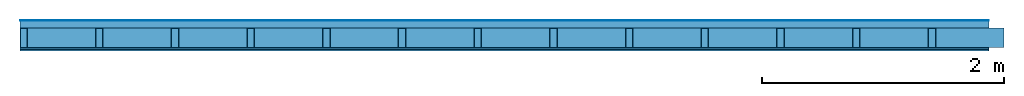
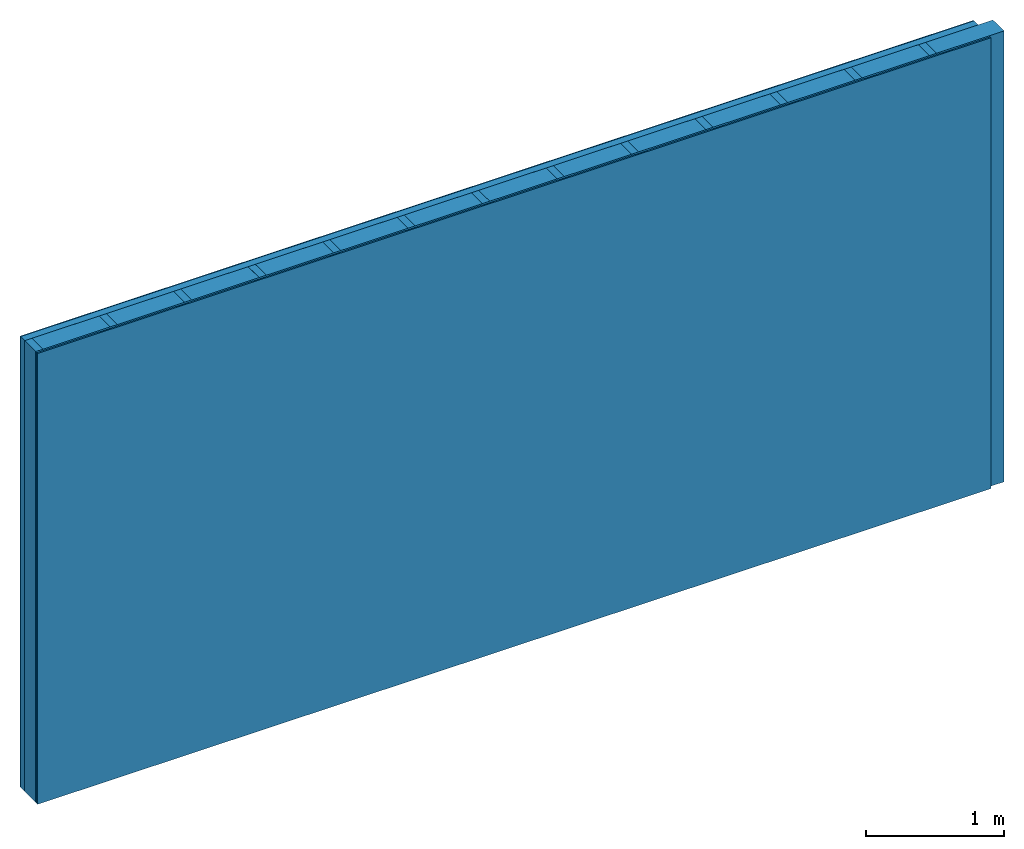
# One storey: 4 plates, 2 members, 1 element without a shape of its own.
"""IFC4 building model written with IfcOpenShell, lengths in metres."""

from ifc_helpers import new_model, si_unit, derived_unit, direction, frame, frame_2d, origin, origin_with_axes, place, context, project, spatial, rectangle, extrude, material, layer, layer_set, type_object, element, aggregate, save


model = new_model("IFC4")

# Units and contexts
plan_context = context("Plan", 3, precision=1e-05, world=origin(), true_north=direction((0.0, 1.0)))
model_context = context("Model", 3, precision=1e-05, world=origin(), true_north=direction((0.0, 1.0)))
ifc_project = project(units=[si_unit("LENGTHUNIT", "METRE"), derived_unit("SOUNDPRESSUREUNIT", [(si_unit("PRESSUREUNIT", "PASCAL", prefix="MICRO"), 0)]), si_unit("ENERGYUNIT", "JOULE", prefix="MEGA"), si_unit("MASSUNIT", "GRAM", prefix="KILO"), derived_unit("THERMALTRANSMITTANCEUNIT", [(si_unit("POWERUNIT", "WATT"), 1), (si_unit("AREAUNIT", "SQUARE_METRE"), -1), (si_unit("THERMODYNAMICTEMPERATUREUNIT", "KELVIN"), -1)]), derived_unit("AREADENSITYUNIT", [(si_unit("MASSUNIT", "GRAM", prefix="KILO"), 1), (si_unit("AREAUNIT", "SQUARE_METRE"), -1)]), derived_unit("USERDEFINED", [(si_unit("ENERGYUNIT", "JOULE", prefix="MEGA"), 1), (si_unit("AREAUNIT", "SQUARE_METRE"), -1)])], contexts=[plan_context, model_context])

# Site, building, storey
site = spatial("IfcSite", under=ifc_project)
building_placement = place(None, origin())
building = spatial("IfcBuilding", under=site, at=building_placement)
storey_placement = place(building_placement, origin())
storey = spatial("IfcBuildingStorey", under=building, at=storey_placement)

# Wall, members, plates
ifc_material_1 = material(Category="04.011")
ifc_layer_1 = layer(ifc_material_1, 0.008, Name="Surface 1")
ifc_material_2 = material(Category="10.009")
ifc_layer_2 = layer(ifc_material_2, 0.06, Name="outside 2nd layer")
ifc_material_3 = material(Name="of the art")
ifc_layer_3 = layer(ifc_material_3, 0.0, Name="Bond")
ifc_layer_4 = layer(None, 0.16, Name="Support")
ifc_material_4 = material(Name="Rigid, of the art")
ifc_layer_5 = layer(ifc_material_4, 0.0, Name="Bond")
ifc_material_5 = material(Name="OSB/3", Category="07.013")
ifc_layer_6 = layer(ifc_material_5, 0.015, Name="1st layer")
ifc_material_6 = material(Category="03.007")
ifc_layer_7 = layer(ifc_material_6, 0.0125, Name="2nd layer")
ifc_material_7 = material(Name="Glued joints")
ifc_layer_8 = layer(ifc_material_7, 0.0, Name="Surface")
ifc_layer_set = layer_set([ifc_layer_1, ifc_layer_2, ifc_layer_3, ifc_layer_4, ifc_layer_5, ifc_layer_6, ifc_layer_7, ifc_layer_8])
wall_type = type_object("IfcWallType", Name="D1188", PredefinedType="NOTDEFINED", material=ifc_layer_set)
wall_placement = place(None, frame((0.0, 0.0, 0.0), z_axis=(0.0, -1.0, 0.0), x_axis=(1.0, 0.0, 0.0)))
wall = element("IfcWall", 1, at=wall_placement, inside=storey, type_object=wall_type, material=ifc_layer_set, Name="Wall #1")
ifc_material_8 = material()
member_1_placement = place(wall_placement, origin())
member_1 = element("IfcMember", 2, at=member_1_placement, material=ifc_material_8, Name="Support", context=plan_context, shape_type="SweptSolid", body=[
    extrude(rectangle(XDim=0.06, YDim=0.16, at=frame_2d((0.03, 0.08), x_axis=(1.0, 0.0))), frame((0.0, 4.0, 0.068), z_axis=(0.0, -1.0, 0.0), x_axis=(1.0, 0.0, 0.0)), (0.0, 0.0, 1.0), 4.0),
    extrude(rectangle(XDim=0.06, YDim=0.16, at=frame_2d((0.03, 0.08), x_axis=(1.0, 0.0))), frame((0.625, 4.0, 0.068), z_axis=(0.0, -1.0, 0.0), x_axis=(1.0, 0.0, 0.0)), (0.0, 0.0, 1.0), 4.0),
    extrude(rectangle(XDim=0.06, YDim=0.16, at=frame_2d((0.03, 0.08), x_axis=(1.0, 0.0))), frame((1.25, 4.0, 0.068), z_axis=(0.0, -1.0, 0.0), x_axis=(1.0, 0.0, 0.0)), (0.0, 0.0, 1.0), 4.0),
    extrude(rectangle(XDim=0.06, YDim=0.16, at=frame_2d((0.03, 0.08), x_axis=(1.0, 0.0))), frame((1.875, 4.0, 0.068), z_axis=(0.0, -1.0, 0.0), x_axis=(1.0, 0.0, 0.0)), (0.0, 0.0, 1.0), 4.0),
    extrude(rectangle(XDim=0.06, YDim=0.16, at=frame_2d((0.03, 0.08), x_axis=(1.0, 0.0))), frame((2.5, 4.0, 0.068), z_axis=(0.0, -1.0, 0.0), x_axis=(1.0, 0.0, 0.0)), (0.0, 0.0, 1.0), 4.0),
    extrude(rectangle(XDim=0.06, YDim=0.16, at=frame_2d((0.03, 0.08), x_axis=(1.0, 0.0))), frame((3.125, 4.0, 0.068), z_axis=(0.0, -1.0, 0.0), x_axis=(1.0, 0.0, 0.0)), (0.0, 0.0, 1.0), 4.0),
    extrude(rectangle(XDim=0.06, YDim=0.16, at=frame_2d((0.03, 0.08), x_axis=(1.0, 0.0))), frame((3.75, 4.0, 0.068), z_axis=(0.0, -1.0, 0.0), x_axis=(1.0, 0.0, 0.0)), (0.0, 0.0, 1.0), 4.0),
    extrude(rectangle(XDim=0.06, YDim=0.16, at=frame_2d((0.03, 0.08), x_axis=(1.0, 0.0))), frame((4.375, 4.0, 0.068), z_axis=(0.0, -1.0, 0.0), x_axis=(1.0, 0.0, 0.0)), (0.0, 0.0, 1.0), 4.0),
    extrude(rectangle(XDim=0.06, YDim=0.16, at=frame_2d((0.03, 0.08), x_axis=(1.0, 0.0))), frame((5.0, 4.0, 0.068), z_axis=(0.0, -1.0, 0.0), x_axis=(1.0, 0.0, 0.0)), (0.0, 0.0, 1.0), 4.0),
    extrude(rectangle(XDim=0.06, YDim=0.16, at=frame_2d((0.03, 0.08), x_axis=(1.0, 0.0))), frame((5.625, 4.0, 0.068), z_axis=(0.0, -1.0, 0.0), x_axis=(1.0, 0.0, 0.0)), (0.0, 0.0, 1.0), 4.0),
    extrude(rectangle(XDim=0.06, YDim=0.16, at=frame_2d((0.03, 0.08), x_axis=(1.0, 0.0))), frame((6.25, 4.0, 0.068), z_axis=(0.0, -1.0, 0.0), x_axis=(1.0, 0.0, 0.0)), (0.0, 0.0, 1.0), 4.0),
    extrude(rectangle(XDim=0.06, YDim=0.16, at=frame_2d((0.03, 0.08), x_axis=(1.0, 0.0))), frame((6.875, 4.0, 0.068), z_axis=(0.0, -1.0, 0.0), x_axis=(1.0, 0.0, 0.0)), (0.0, 0.0, 1.0), 4.0),
    extrude(rectangle(XDim=0.06, YDim=0.16, at=frame_2d((0.03, 0.08), x_axis=(1.0, 0.0))), frame((7.5, 4.0, 0.068), z_axis=(0.0, -1.0, 0.0), x_axis=(1.0, 0.0, 0.0)), (0.0, 0.0, 1.0), 4.0),
])
ifc_material_9 = material()
member_2_placement = place(wall_placement, origin())
member_2 = element("IfcMember", 3, at=member_2_placement, material=ifc_material_9, Name="Cavity", context=plan_context, shape_type="SweptSolid", body=[
    extrude(rectangle(XDim=0.565, YDim=0.16, at=frame_2d((0.2825, 0.08), x_axis=(1.0, 0.0))), frame((0.06, 4.0, 0.068), z_axis=(0.0, -1.0, 0.0), x_axis=(1.0, 0.0, 0.0)), (0.0, 0.0, 1.0), 4.0),
    extrude(rectangle(XDim=0.565, YDim=0.16, at=frame_2d((0.2825, 0.08), x_axis=(1.0, 0.0))), frame((0.685, 4.0, 0.068), z_axis=(0.0, -1.0, 0.0), x_axis=(1.0, 0.0, 0.0)), (0.0, 0.0, 1.0), 4.0),
    extrude(rectangle(XDim=0.565, YDim=0.16, at=frame_2d((0.2825, 0.08), x_axis=(1.0, 0.0))), frame((1.31, 4.0, 0.068), z_axis=(0.0, -1.0, 0.0), x_axis=(1.0, 0.0, 0.0)), (0.0, 0.0, 1.0), 4.0),
    extrude(rectangle(XDim=0.565, YDim=0.16, at=frame_2d((0.2825, 0.08), x_axis=(1.0, 0.0))), frame((1.935, 4.0, 0.068), z_axis=(0.0, -1.0, 0.0), x_axis=(1.0, 0.0, 0.0)), (0.0, 0.0, 1.0), 4.0),
    extrude(rectangle(XDim=0.565, YDim=0.16, at=frame_2d((0.2825, 0.08), x_axis=(1.0, 0.0))), frame((2.56, 4.0, 0.068), z_axis=(0.0, -1.0, 0.0), x_axis=(1.0, 0.0, 0.0)), (0.0, 0.0, 1.0), 4.0),
    extrude(rectangle(XDim=0.565, YDim=0.16, at=frame_2d((0.2825, 0.08), x_axis=(1.0, 0.0))), frame((3.185, 4.0, 0.068), z_axis=(0.0, -1.0, 0.0), x_axis=(1.0, 0.0, 0.0)), (0.0, 0.0, 1.0), 4.0),
    extrude(rectangle(XDim=0.565, YDim=0.16, at=frame_2d((0.2825, 0.08), x_axis=(1.0, 0.0))), frame((3.81, 4.0, 0.068), z_axis=(0.0, -1.0, 0.0), x_axis=(1.0, 0.0, 0.0)), (0.0, 0.0, 1.0), 4.0),
    extrude(rectangle(XDim=0.565, YDim=0.16, at=frame_2d((0.2825, 0.08), x_axis=(1.0, 0.0))), frame((4.435, 4.0, 0.068), z_axis=(0.0, -1.0, 0.0), x_axis=(1.0, 0.0, 0.0)), (0.0, 0.0, 1.0), 4.0),
    extrude(rectangle(XDim=0.565, YDim=0.16, at=frame_2d((0.2825, 0.08), x_axis=(1.0, 0.0))), frame((5.06, 4.0, 0.068), z_axis=(0.0, -1.0, 0.0), x_axis=(1.0, 0.0, 0.0)), (0.0, 0.0, 1.0), 4.0),
    extrude(rectangle(XDim=0.565, YDim=0.16, at=frame_2d((0.2825, 0.08), x_axis=(1.0, 0.0))), frame((5.685, 4.0, 0.068), z_axis=(0.0, -1.0, 0.0), x_axis=(1.0, 0.0, 0.0)), (0.0, 0.0, 1.0), 4.0),
    extrude(rectangle(XDim=0.565, YDim=0.16, at=frame_2d((0.2825, 0.08), x_axis=(1.0, 0.0))), frame((6.31, 4.0, 0.068), z_axis=(0.0, -1.0, 0.0), x_axis=(1.0, 0.0, 0.0)), (0.0, 0.0, 1.0), 4.0),
    extrude(rectangle(XDim=0.565, YDim=0.16, at=frame_2d((0.2825, 0.08), x_axis=(1.0, 0.0))), frame((6.935, 4.0, 0.068), z_axis=(0.0, -1.0, 0.0), x_axis=(1.0, 0.0, 0.0)), (0.0, 0.0, 1.0), 4.0),
    extrude(rectangle(XDim=0.565, YDim=0.16, at=frame_2d((0.2825, 0.08), x_axis=(1.0, 0.0))), frame((7.56, 4.0, 0.068), z_axis=(0.0, -1.0, 0.0), x_axis=(1.0, 0.0, 0.0)), (0.0, 0.0, 1.0), 4.0),
])
plate_1_placement = place(wall_placement, origin())
plate_1 = element("IfcPlate", 4, at=plate_1_placement, material=ifc_material_1, Name="Surface 1", context=plan_context, shape_type="SweptSolid", body=[
    extrude(rectangle(XDim=8.0, YDim=4.0, at=frame_2d((4.0, 2.0), x_axis=(1.0, 0.0))), origin_with_axes(), (0.0, 0.0, 1.0), 0.008),
])
plate_2_placement = place(wall_placement, origin())
plate_2 = element("IfcPlate", 5, at=plate_2_placement, material=ifc_material_2, Name="outside 2nd layer", context=plan_context, shape_type="SweptSolid", body=[
    extrude(rectangle(XDim=8.0, YDim=4.0, at=frame_2d((4.0, 2.0), x_axis=(1.0, 0.0))), frame((0.0, 0.0, 0.008), z_axis=(0.0, 0.0, 1.0), x_axis=(1.0, 0.0, 0.0)), (0.0, 0.0, 1.0), 0.06),
])
plate_3_placement = place(wall_placement, origin())
plate_3 = element("IfcPlate", 6, at=plate_3_placement, material=ifc_material_5, Name="1st layer", context=plan_context, shape_type="SweptSolid", body=[
    extrude(rectangle(XDim=8.0, YDim=4.0, at=frame_2d((4.0, 2.0), x_axis=(1.0, 0.0))), frame((0.0, 0.0, 0.228), z_axis=(0.0, 0.0, 1.0), x_axis=(1.0, 0.0, 0.0)), (0.0, 0.0, 1.0), 0.015),
])
plate_4_placement = place(wall_placement, origin())
plate_4 = element("IfcPlate", 7, at=plate_4_placement, material=ifc_material_6, Name="2nd layer", context=plan_context, shape_type="SweptSolid", body=[
    extrude(rectangle(XDim=8.0, YDim=4.0, at=frame_2d((4.0, 2.0), x_axis=(1.0, 0.0))), frame((0.0, 0.0, 0.243), z_axis=(0.0, 0.0, 1.0), x_axis=(1.0, 0.0, 0.0)), (0.0, 0.0, 1.0), 0.0125),
])
aggregate(wall, [plate_1, plate_2, member_1, member_2, plate_3, plate_4])

save(model, "model.ifc")
